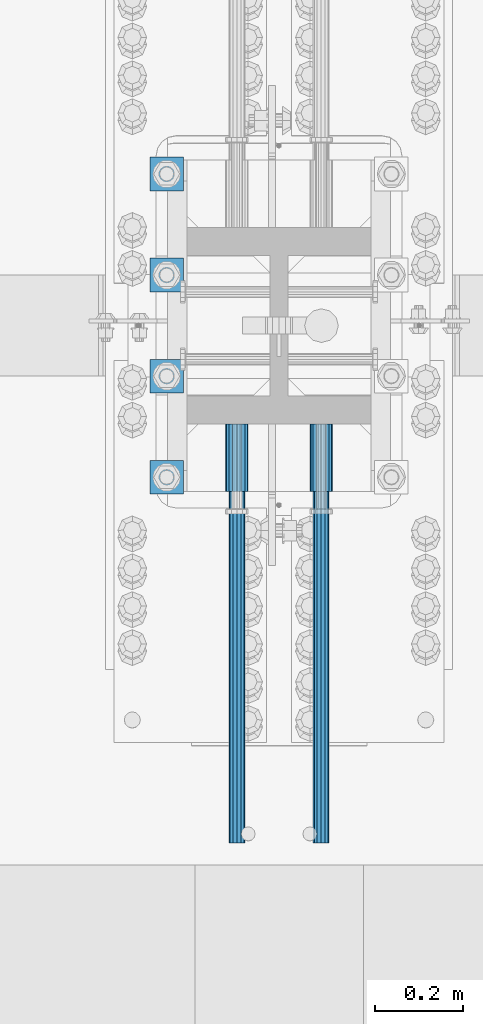
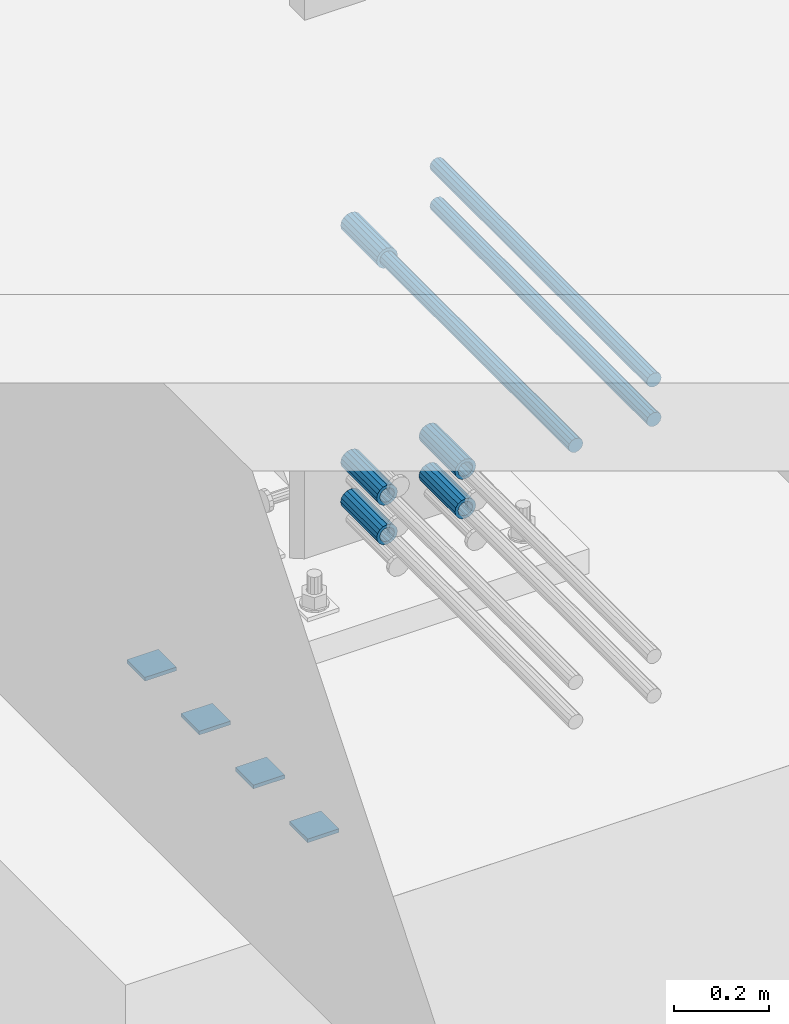
# One storey, part 1302 of 1763: 12 beams, 5 elements without a shape of their own.
"""IFC2X3 building model written with IfcOpenShell, lengths in millimetres."""

import ifcopenshell
import ifcopenshell.guid

model = None  # the IFC model being written
_history = None  # IfcOwnerHistory: only IFC2X3 demands one
_inside = {}  # id of a spatial element -> (the spatial element, [elements in it])
_under = {}  # id of a project, library or spatial element -> (it, [spatial elements below it])
_declared = {}  # id of a project -> (the project, [libraries it declares])
_typed = {}  # id of a type object -> (the type object, [elements of that type])
_made_of = {}  # id of a material, layer set ... -> (it, [elements and type objects made of it])


def new_model(schema):
    """Start an empty IFC model of exactly this schema.

    Asked for "IFC4X3", IfcOpenShell would pick the latest addendum, in which some entities
    have other attributes; the version numbers below select the first issue.
    IFC2X3 requires an IfcOwnerHistory on every rooted entity: one is made here for all.
    """
    global model, _history
    if schema == "IFC4X3":
        model = ifcopenshell.file(schema_version=(4, 3, 0, 0))
    else:
        model = ifcopenshell.file(schema=schema)
    _inside.clear()
    _under.clear()
    _declared.clear()
    _typed.clear()
    _made_of.clear()
    _history = None
    if model.schema == "IFC2X3":
        org = make("IfcOrganization", Name="unknown")
        user = make(
            "IfcPersonAndOrganization",
            ThePerson=make("IfcPerson", FamilyName="unknown"),
            TheOrganization=org,
        )
        app = make(
            "IfcApplication",
            ApplicationDeveloper=org,
            Version="unknown",
            ApplicationFullName="unknown",
            ApplicationIdentifier="unknown",
        )
        _history = make(
            "IfcOwnerHistory",
            OwningUser=user,
            OwningApplication=app,
            ChangeAction="ADDED",
            CreationDate=0,
        )
    return model


def make(cls, **values):
    """One entity of the class cls with the attributes given. An attribute that is None is left unset."""
    return model.create_entity(
        cls, **{name: value for name, value in values.items() if value is not None}
    )


def rooted(cls, **values):
    """An entity with a GlobalId (a new one), such as an element, a storey or a relation."""
    return make(cls, GlobalId=ifcopenshell.guid.new(), OwnerHistory=_history, **values)


def si_unit(unit_type, name, prefix=None):
    """IfcSIUnit, for example si_unit("LENGTHUNIT", "METRE", prefix="MILLI")."""
    return make("IfcSIUnit", UnitType=unit_type, Prefix=prefix, Name=name)


def assignment(units):
    """IfcUnitAssignment: the units of a project."""
    return None if units is None else make("IfcUnitAssignment", Units=units)


def point(xyz):
    """IfcCartesianPoint."""
    return None if xyz is None else make("IfcCartesianPoint", Coordinates=xyz)


def direction(xyz):
    """IfcDirection."""
    return None if xyz is None else make("IfcDirection", DirectionRatios=xyz)


def frame(location, z_axis=None, x_axis=None):
    """IfcAxis2Placement3D, a coordinate frame: its origin and axes. An axis left out is left unset."""
    return make(
        "IfcAxis2Placement3D",
        Location=point(location),
        Axis=direction(z_axis),
        RefDirection=direction(x_axis),
    )


def origin_with_axes():
    """The frame at (0, 0, 0) with the z axis (0, 0, 1) and the x axis (1, 0, 0) written out."""
    return frame((0.0, 0.0, 0.0), z_axis=(0.0, 0.0, 1.0), x_axis=(1.0, 0.0, 0.0))


def place(relative_to, where):
    """IfcLocalPlacement: puts the frame where relative to a parent placement (None: the world)."""
    return make(
        "IfcLocalPlacement", PlacementRelTo=relative_to, RelativePlacement=where
    )


def context(
    kind, dimensions, precision=None, world=None, true_north=None, identifier=None
):
    """IfcGeometricRepresentationContext, for example the 3D "Model" context."""
    return make(
        "IfcGeometricRepresentationContext",
        ContextIdentifier=identifier,
        ContextType=kind,
        CoordinateSpaceDimension=dimensions,
        Precision=precision,
        WorldCoordinateSystem=world,
        TrueNorth=true_north,
    )


def subcontext(parent, identifier, kind, view, scale=None):
    """IfcGeometricRepresentationSubContext, for example "Body" below "Model"."""
    return make(
        "IfcGeometricRepresentationSubContext",
        ContextIdentifier=identifier,
        ContextType=kind,
        ParentContext=parent,
        TargetScale=scale,
        TargetView=view,
    )


def project(units=None, contexts=None):
    """IfcProject with its units and contexts."""
    return rooted(
        "IfcProject",
        Name="project",
        RepresentationContexts=contexts,
        UnitsInContext=assignment(units),
    )


def spatial(cls, under=None, at=None, **own):
    """A site, building, storey or space (cls), placed at a placement, below another one or the project."""
    s = rooted(cls, ObjectPlacement=at, **own)
    if under is not None:
        _under.setdefault(under.id(), (under, []))[1].append(s)
    return s


def faces_of(points, faces, orient=None, outer=None):
    """IfcFace entities. A face is a list of loops; a loop is a list of indices into points, from 0.

    orient and outer hold one flag for each loop. By default every Orientation is true, the
    first loop of a face is its IfcFaceOuterBound and the others are IfcFaceBound.
    """
    made = []
    for i, loops in enumerate(faces):
        bounds = []
        for j, loop in enumerate(loops):
            is_outer = j == 0 if outer is None else outer[i][j]
            bounds.append(
                make(
                    "IfcFaceOuterBound" if is_outer else "IfcFaceBound",
                    Bound=make("IfcPolyLoop", Polygon=[points[k] for k in loop]),
                    Orientation=True if orient is None else orient[i][j],
                )
            )
        made.append(make("IfcFace", Bounds=bounds))
    return made


def faceted_brep(points, faces, orient=None, outer=None, voids=None):
    """IfcFacetedBrep: a solid bounded by flat faces; with voids (closed shells), ...WithVoids."""
    shared = [point(p) for p in points]
    hull = make("IfcClosedShell", CfsFaces=faces_of(shared, faces, orient, outer))
    if voids is None:
        return make("IfcFacetedBrep", Outer=hull)
    return make(
        "IfcFacetedBrepWithVoids",
        Outer=hull,
        Voids=[
            make(cls, CfsFaces=faces_of(shared, fs, o, b)) for cls, fs, o, b in voids
        ],
    )


def shape(context_of_items, identifier, shape_type, items):
    """IfcShapeRepresentation: the items that make up one representation, for example the "Body"."""
    return make(
        "IfcShapeRepresentation",
        ContextOfItems=context_of_items,
        RepresentationIdentifier=identifier,
        RepresentationType=shape_type,
        Items=items,
    )


def material(Name=None, Category=None):
    """IfcMaterial."""
    return make("IfcMaterial", Name=Name, Category=Category)


def made_of(thing, what):
    """Note that an element or type object is made of a material, layer set ...; save() writes the relation."""
    if what is not None:
        _made_of.setdefault(what.id(), (what, []))[1].append(thing)
    return thing


def type_object(cls, material=None, **own):
    """A type object (cls), such as IfcWallType, which elements share."""
    return made_of(rooted(cls, **own), material)


def element(
    cls,
    number,
    at=None,
    inside=None,
    cuts=None,
    type_object=None,
    material=None,
    context=None,
    identifier="Body",
    shape_type=None,
    held_by="IfcProductDefinitionShape",
    body=None,
    shapes=None,
    **own,
):
    """One element of the class cls, such as IfcWall. Its Tag is "e" and its number.

    at: its placement. inside: the storey or other place that contains it. cuts: it is an
    opening in that element (IfcRelVoidsElement). A single representation is given by context,
    identifier, shape_type and body (its items); several are given by shapes. held_by: the class
    of the entity that holds the representations. save() writes the other relations.
    """
    e = rooted(cls, Tag="e%d" % number, ObjectPlacement=at, **own)
    if body is not None:
        shapes = [shape(context, identifier, shape_type, body)]
    if shapes is not None:
        e.Representation = make(held_by, Representations=shapes)
    if inside is not None:
        _inside.setdefault(inside.id(), (inside, []))[1].append(e)
    if cuts is not None:
        rooted(
            "IfcRelVoidsElement", RelatingBuildingElement=cuts, RelatedOpeningElement=e
        )
    if type_object is not None:
        _typed.setdefault(type_object.id(), (type_object, []))[1].append(e)
    return made_of(e, material)


def aggregate(whole, parts):
    """IfcRelAggregates: a whole, such as a stair, and the parts it consists of."""
    return rooted("IfcRelAggregates", RelatingObject=whole, RelatedObjects=parts)


def save(model, path):
    """Write the relations noted so far, then the file.

    IfcRelAggregates (storeys below a building ...), IfcRelContainedInSpatialStructure (elements
    in a storey), IfcRelDefinesByType, IfcRelAssociatesMaterial and IfcRelDeclares: one each for
    every whole, place, type object, material and project.
    """
    for whole, parts in _under.values():
        aggregate(whole, parts)
    for where, things in _inside.values():
        rooted(
            "IfcRelContainedInSpatialStructure",
            RelatedElements=things,
            RelatingStructure=where,
        )
    for kind, things in _typed.values():
        rooted("IfcRelDefinesByType", RelatedObjects=things, RelatingType=kind)
    for what, things in _made_of.values():
        rooted("IfcRelAssociatesMaterial", RelatedObjects=things, RelatingMaterial=what)
    for by, libraries in _declared.values():
        rooted("IfcRelDeclares", RelatingContext=by, RelatedDefinitions=libraries)
    model.write(path)


model = new_model("IFC2X3")

# Units and contexts
model_context = context("Model", 3, precision=1e-05, world=origin_with_axes())
body_context = subcontext(model_context, "Body", "Model", "MODEL_VIEW")
ifc_project = project(units=[si_unit("LENGTHUNIT", "METRE", prefix="MILLI"), si_unit("AREAUNIT", "SQUARE_METRE"), si_unit("VOLUMEUNIT", "CUBIC_METRE"), si_unit("MASSUNIT", "GRAM", prefix="KILO"), si_unit("TIMEUNIT", "SECOND"), si_unit("PLANEANGLEUNIT", "RADIAN"), si_unit("SOLIDANGLEUNIT", "STERADIAN"), si_unit("THERMODYNAMICTEMPERATUREUNIT", "DEGREE_CELSIUS"), si_unit("LUMINOUSINTENSITYUNIT", "LUMEN")], contexts=[model_context])

# Site, building, storey
site_placement = place(None, origin_with_axes())
site = spatial("IfcSite", under=ifc_project, at=site_placement, CompositionType="ELEMENT")
building_placement = place(site_placement, origin_with_axes())
building = spatial("IfcBuilding", under=site, at=building_placement, Name="Undefined", CompositionType="ELEMENT")
storey_placement = place(building_placement, origin_with_axes())
storey = spatial("IfcBuildingStorey", under=building, at=storey_placement, Name="Undefined", CompositionType="ELEMENT", Elevation=0.0)

# Assembly, beams
assembly_1_placement = place(storey_placement, origin_with_axes())
assembly_1 = element("IfcElementAssembly", 1, at=assembly_1_placement, inside=storey, Name="TEMPLATE", AssemblyPlace="NOTDEFINED", PredefinedType="RIGID_FRAME")
ifc_material_1 = material(Name="STEEL/A36")
beam_type_1 = type_object("IfcBeamType", PredefinedType="NOTDEFINED")
beam_1_placement = place(assembly_1_placement, frame((-24281.8372736984, 76.1999999999981, 3348.0375), z_axis=(1.0, 0.0, 0.0), x_axis=(0.0, 1.0, 0.0)))
beam_1 = element("IfcBeam", 2, at=beam_1_placement, type_object=beam_type_1, material=ifc_material_1, Name="WASHER PLATE", context=body_context, shape_type="Brep", body=[
    faceted_brep([(0.0, 4.76249999999709, -38.1000000000004), (0.0, 4.76249999999709, 38.1000000000004), (76.2000000000007, 4.76249999999982, 38.0999999999985), (76.2000000000007, 4.76249999999982, -38.0999999999985), (0.0, -4.76249999999709, 38.1000000000004), (76.2000000000007, -4.76249999999982, 38.0999999999985), (0.0, -4.76249999999709, -38.1000000000004), (76.2000000000007, -4.76249999999982, -38.0999999999985)], [[[0, 1, 2, 3]], [[1, 4, 5, 2]], [[4, 6, 7, 5]], [[6, 0, 3, 7]], [[5, 7, 3, 2]], [[6, 4, 1, 0]]]),
])
beam_2_placement = place(assembly_1_placement, frame((-24281.8372736984, 304.799999999998, 3348.0375), z_axis=(1.0, 0.0, 0.0), x_axis=(0.0, 1.0, 0.0)))
beam_2 = element("IfcBeam", 3, at=beam_2_placement, type_object=beam_type_1, material=ifc_material_1, Name="WASHER PLATE", context=body_context, shape_type="Brep", body=[
    faceted_brep([(0.0, 4.76249999999709, -38.1000000000004), (0.0, 4.76249999999709, 38.1000000000004), (76.2000000000007, 4.76249999999982, 38.0999999999985), (76.2000000000007, 4.76249999999982, -38.0999999999985), (0.0, -4.76249999999709, 38.1000000000004), (76.2000000000007, -4.76249999999982, 38.0999999999985), (0.0, -4.76249999999709, -38.1000000000004), (76.2000000000007, -4.76249999999982, -38.0999999999985)], [[[0, 1, 2, 3]], [[1, 4, 5, 2]], [[4, 6, 7, 5]], [[6, 0, 3, 7]], [[5, 7, 3, 2]], [[6, 4, 1, 0]]]),
])
beam_3_placement = place(assembly_1_placement, frame((-24281.8372736984, 533.399999999998, 3348.0375), z_axis=(1.0, 0.0, 0.0), x_axis=(0.0, 1.0, 0.0)))
beam_3 = element("IfcBeam", 4, at=beam_3_placement, type_object=beam_type_1, material=ifc_material_1, Name="WASHER PLATE", context=body_context, shape_type="Brep", body=[
    faceted_brep([(0.0, 4.76249999999709, -38.1000000000004), (0.0, 4.76249999999709, 38.1000000000004), (76.2000000000007, 4.76249999999982, 38.0999999999985), (76.2000000000007, 4.76249999999982, -38.0999999999985), (0.0, -4.76249999999709, 38.1000000000004), (76.2000000000007, -4.76249999999982, 38.0999999999985), (0.0, -4.76249999999709, -38.1000000000004), (76.2000000000007, -4.76249999999982, -38.0999999999985)], [[[0, 1, 2, 3]], [[1, 4, 5, 2]], [[4, 6, 7, 5]], [[6, 0, 3, 7]], [[5, 7, 3, 2]], [[6, 4, 1, 0]]]),
])
beam_4_placement = place(assembly_1_placement, frame((-24281.8372736984, 761.999999999998, 3348.0375), z_axis=(1.0, 0.0, 0.0), x_axis=(0.0, 1.0, 0.0)))
beam_4 = element("IfcBeam", 5, at=beam_4_placement, type_object=beam_type_1, material=ifc_material_1, Name="WASHER PLATE", context=body_context, shape_type="Brep", body=[
    faceted_brep([(0.0, 4.76249999999709, -38.1000000000004), (0.0, 4.76249999999709, 38.1000000000004), (76.2000000000007, 4.76249999999982, 38.0999999999985), (76.2000000000007, 4.76249999999982, -38.0999999999985), (0.0, -4.76249999999709, 38.1000000000004), (76.2000000000007, -4.76249999999982, 38.0999999999985), (0.0, -4.76249999999709, -38.1000000000004), (76.2000000000007, -4.76249999999982, -38.0999999999985)], [[[0, 1, 2, 3]], [[1, 4, 5, 2]], [[4, 6, 7, 5]], [[6, 0, 3, 7]], [[5, 7, 3, 2]], [[6, 4, 1, 0]]]),
])
aggregate(assembly_1, [beam_1, beam_2, beam_3, beam_4])

assembly_2_placement = place(storey_placement, origin_with_axes())
assembly_2 = element("IfcElementAssembly", 6, at=assembly_2_placement, inside=storey, Name="COLUMN", AssemblyPlace="NOTDEFINED", PredefinedType="RIGID_FRAME")
ifc_material_2 = material(Name="STEEL/A706-GR.80")
beam_type_2 = type_object("IfcBeamType", PredefinedType="NOTDEFINED")
beam_5_placement = place(assembly_2_placement, frame((-24123.0872736984, 234.764353525459, 4064.0), z_axis=(0.0, 0.0, 1.0), x_axis=(0.0, -1.0, 0.0)))
beam_5 = element("IfcBeam", 7, at=beam_5_placement, type_object=beam_type_2, material=ifc_material_2, Name="HALF COUPLER F", context=body_context, shape_type="Brep", body=[
    faceted_brep([(32.7659999999996, -8.95349999999962, -15.507916905568), (32.7659999999996, 0.0, -17.9070000000002), (32.7659999999996, 8.95349999999962, -15.507916905568), (32.7659999999996, 15.507916905568, -8.95350000000008), (32.7659999999996, 17.9069999999992, 0.0), (32.7659999999996, 15.507916905568, 8.95350000000008), (32.7659999999996, 8.95349999999962, 15.507916905568), (32.7659999999996, 0.0, 17.9070000000002), (32.7659999999996, -8.95349999999962, 15.507916905568), (32.7659999999996, -15.507916905568, 8.95350000000008), (32.7659999999996, -17.9069999999992, 0.0), (32.7659999999996, -15.507916905568, -8.95350000000008), (152.400103102711, -15.507916905568, 8.95350000000008), (152.400103102711, -8.95349999999962, 15.507916905568), (152.400103102711, -17.9069999999992, 0.0), (152.400103102711, -15.507916905568, -8.95350000000008), (152.400103102711, -8.95349999999962, -15.507916905568), (152.400103102711, 0.0, -17.9070000000002), (152.400103102711, 8.95349999999962, -15.507916905568), (152.400103102711, 15.507916905568, -8.95350000000008), (152.400103102711, 17.9069999999992, 0.0), (152.400103102711, 15.507916905568, 8.95350000000008), (152.400103102711, 8.95349999999962, 15.507916905568), (152.400103102711, 0.0, 17.9070000000002), (0.0, -23.466540125788, 9.72015918207308), (0.0, -17.9605122421381, 17.9605122421385), (0.0, -9.72015918207398, 23.4665401257867), (0.0, 0.0, 25.4000000000001), (0.0, 9.72015918207398, 23.4665401257867), (0.0, 17.9605122421381, 17.9605122421385), (0.0, 23.466540125788, 9.72015918207308), (0.0, 25.4000000000015, 0.0), (0.0, 23.466540125788, -9.72015918207308), (0.0, 17.9605122421381, -17.9605122421385), (0.0, 9.72015918207398, -23.4665401257867), (0.0, 0.0, -25.4000000000001), (0.0, -9.72015918207398, -23.4665401257867), (0.0, -17.9605122421381, -17.9605122421385), (0.0, -23.466540125788, -9.72015918207308), (0.0, -25.4000000000015, 0.0), (152.400103102711, -25.4000000000015, 0.0), (152.400103102711, -23.466540125788, 9.72015918207308), (152.400103102711, -17.9605122421381, 17.9605122421385), (152.400103102711, -9.72015918207398, 23.4665401257867), (152.400103102711, 0.0, 25.4000000000001), (152.400103102711, 9.72015918207398, 23.4665401257867), (152.400103102711, 17.9605122421381, 17.9605122421385), (152.400103102711, 23.466540125788, 9.72015918207308), (152.400103102711, 25.4000000000015, 0.0), (152.400103102711, 23.466540125788, -9.72015918207308), (152.400103102711, 17.9605122421381, -17.9605122421385), (152.400103102711, 9.72015918207398, -23.4665401257867), (152.400103102711, 0.0, -25.4000000000001), (152.400103102711, -9.72015918207398, -23.4665401257867), (152.400103102711, -17.9605122421381, -17.9605122421385), (152.400103102711, -23.466540125788, -9.72015918207308)], [[[0, 1, 2, 3, 4, 5, 6, 7, 8, 9, 10, 11]], [[12, 9, 8, 13]], [[14, 10, 9, 12]], [[15, 11, 10, 14]], [[16, 0, 11, 15]], [[17, 1, 0, 16]], [[18, 2, 1, 17]], [[19, 3, 2, 18]], [[20, 4, 3, 19]], [[21, 5, 4, 20]], [[22, 6, 5, 21]], [[23, 7, 6, 22]], [[13, 8, 7, 23]], [[24, 25, 26, 27, 28, 29, 30, 31, 32, 33, 34, 35, 36, 37, 38, 39]], [[24, 39, 40, 41]], [[25, 24, 41, 42]], [[26, 25, 42, 43]], [[27, 26, 43, 44]], [[28, 27, 44, 45]], [[29, 28, 45, 46]], [[30, 29, 46, 47]], [[31, 30, 47, 48]], [[32, 31, 48, 49]], [[33, 32, 49, 50]], [[34, 33, 50, 51]], [[35, 34, 51, 52]], [[36, 35, 52, 53]], [[37, 36, 53, 54]], [[38, 37, 54, 55]], [[39, 38, 55, 40]], [[54, 53, 52, 51, 50, 49, 48, 47, 46, 45, 44, 43, 42, 41, 40, 55], [21, 20, 19, 18, 17, 16, 15, 14, 12, 13, 23, 22]]]),
])
beam_6_placement = place(assembly_2_placement, frame((-23932.5872736985, 234.764422260983, 4064.0), z_axis=(0.0, 0.0, 1.0), x_axis=(0.0, -1.0, 0.0)))
beam_6 = element("IfcBeam", 8, at=beam_6_placement, type_object=beam_type_2, material=ifc_material_2, Name="HALF COUPLER F", context=body_context, shape_type="Brep", body=[
    faceted_brep([(32.7659999999996, -8.95349999999962, -15.507916905568), (32.7659999999996, 0.0, -17.9070000000002), (32.7659999999996, 8.95349999999962, -15.507916905568), (32.7659999999996, 15.507916905568, -8.95350000000008), (32.7659999999996, 17.9069999999992, 0.0), (32.7659999999996, 15.507916905568, 8.95350000000008), (32.7659999999996, 8.95349999999962, 15.507916905568), (32.7659999999996, 0.0, 17.9070000000002), (32.7659999999996, -8.95349999999962, 15.507916905568), (32.7659999999996, -15.507916905568, 8.95350000000008), (32.7659999999996, -17.9069999999992, 0.0), (32.7659999999996, -15.507916905568, -8.95350000000008), (152.400103102711, -15.507916905568, 8.95350000000008), (152.400103102711, -8.95349999999962, 15.507916905568), (152.400103102711, -17.9069999999992, 0.0), (152.400103102711, -15.507916905568, -8.95350000000008), (152.400103102711, -8.95349999999962, -15.507916905568), (152.400103102711, 0.0, -17.9070000000002), (152.400103102711, 8.95349999999962, -15.507916905568), (152.400103102711, 15.507916905568, -8.95350000000008), (152.400103102711, 17.9069999999992, 0.0), (152.400103102711, 15.507916905568, 8.95350000000008), (152.400103102711, 8.95349999999962, 15.507916905568), (152.400103102711, 0.0, 17.9070000000002), (0.0, -23.466540125788, 9.72015918207308), (0.0, -17.9605122421381, 17.9605122421385), (0.0, -9.72015918207398, 23.4665401257867), (0.0, 0.0, 25.4000000000001), (0.0, 9.72015918207398, 23.4665401257867), (0.0, 17.9605122421381, 17.9605122421385), (0.0, 23.466540125788, 9.72015918207308), (0.0, 25.4000000000015, 0.0), (0.0, 23.466540125788, -9.72015918207308), (0.0, 17.9605122421381, -17.9605122421385), (0.0, 9.72015918207398, -23.4665401257867), (0.0, 0.0, -25.4000000000001), (0.0, -9.72015918207398, -23.4665401257867), (0.0, -17.9605122421381, -17.9605122421385), (0.0, -23.466540125788, -9.72015918207308), (0.0, -25.4000000000015, 0.0), (152.400103102711, -25.4000000000015, 0.0), (152.400103102711, -23.466540125788, 9.72015918207308), (152.400103102711, -17.9605122421381, 17.9605122421385), (152.400103102711, -9.72015918207398, 23.4665401257867), (152.400103102711, 0.0, 25.4000000000001), (152.400103102711, 9.72015918207398, 23.4665401257867), (152.400103102711, 17.9605122421381, 17.9605122421385), (152.400103102711, 23.466540125788, 9.72015918207308), (152.400103102711, 25.4000000000015, 0.0), (152.400103102711, 23.466540125788, -9.72015918207308), (152.400103102711, 17.9605122421381, -17.9605122421385), (152.400103102711, 9.72015918207398, -23.4665401257867), (152.400103102711, 0.0, -25.4000000000001), (152.400103102711, -9.72015918207398, -23.4665401257867), (152.400103102711, -17.9605122421381, -17.9605122421385), (152.400103102711, -23.466540125788, -9.72015918207308)], [[[0, 1, 2, 3, 4, 5, 6, 7, 8, 9, 10, 11]], [[12, 9, 8, 13]], [[14, 10, 9, 12]], [[15, 11, 10, 14]], [[16, 0, 11, 15]], [[17, 1, 0, 16]], [[18, 2, 1, 17]], [[19, 3, 2, 18]], [[20, 4, 3, 19]], [[21, 5, 4, 20]], [[22, 6, 5, 21]], [[23, 7, 6, 22]], [[13, 8, 7, 23]], [[24, 25, 26, 27, 28, 29, 30, 31, 32, 33, 34, 35, 36, 37, 38, 39]], [[24, 39, 40, 41]], [[25, 24, 41, 42]], [[26, 25, 42, 43]], [[27, 26, 43, 44]], [[28, 27, 44, 45]], [[29, 28, 45, 46]], [[30, 29, 46, 47]], [[31, 30, 47, 48]], [[32, 31, 48, 49]], [[33, 32, 49, 50]], [[34, 33, 50, 51]], [[35, 34, 51, 52]], [[36, 35, 52, 53]], [[37, 36, 53, 54]], [[38, 37, 54, 55]], [[39, 38, 55, 40]], [[54, 53, 52, 51, 50, 49, 48, 47, 46, 45, 44, 43, 42, 41, 40, 55], [21, 20, 19, 18, 17, 16, 15, 14, 12, 13, 23, 22]]]),
])
beam_7_placement = place(assembly_2_placement, frame((-24123.0872736984, 234.764353525458, 4165.6), z_axis=(0.0, 0.0, 1.0), x_axis=(0.0, -1.0, 0.0)))
beam_7 = element("IfcBeam", 9, at=beam_7_placement, type_object=beam_type_2, material=ifc_material_2, Name="HALF COUPLER F", context=body_context, shape_type="Brep", body=[
    faceted_brep([(32.7659999999996, -8.95349999999962, -15.507916905568), (32.7659999999996, 0.0, -17.9070000000002), (32.7659999999996, 8.95349999999962, -15.507916905568), (32.7659999999996, 15.507916905568, -8.95350000000008), (32.7659999999996, 17.9069999999992, 0.0), (32.7659999999996, 15.507916905568, 8.95350000000008), (32.7659999999996, 8.95349999999962, 15.507916905568), (32.7659999999996, 0.0, 17.9070000000002), (32.7659999999996, -8.95349999999962, 15.507916905568), (32.7659999999996, -15.507916905568, 8.95350000000008), (32.7659999999996, -17.9069999999992, 0.0), (32.7659999999996, -15.507916905568, -8.95350000000008), (152.400103102711, -15.507916905568, 8.95350000000008), (152.400103102711, -8.95349999999962, 15.507916905568), (152.400103102711, -17.9069999999992, 0.0), (152.400103102711, -15.507916905568, -8.95350000000008), (152.400103102711, -8.95349999999962, -15.507916905568), (152.400103102711, 0.0, -17.9070000000002), (152.400103102711, 8.95349999999962, -15.507916905568), (152.400103102711, 15.507916905568, -8.95350000000008), (152.400103102711, 17.9069999999992, 0.0), (152.400103102711, 15.507916905568, 8.95350000000008), (152.400103102711, 8.95349999999962, 15.507916905568), (152.400103102711, 0.0, 17.9070000000002), (0.0, -23.466540125788, 9.72015918207308), (0.0, -17.9605122421381, 17.9605122421385), (0.0, -9.72015918207398, 23.4665401257867), (0.0, 0.0, 25.4000000000001), (0.0, 9.72015918207398, 23.4665401257867), (0.0, 17.9605122421381, 17.9605122421385), (0.0, 23.466540125788, 9.72015918207308), (0.0, 25.4000000000015, 0.0), (0.0, 23.466540125788, -9.72015918207308), (0.0, 17.9605122421381, -17.9605122421385), (0.0, 9.72015918207398, -23.4665401257867), (0.0, 0.0, -25.4000000000001), (0.0, -9.72015918207398, -23.4665401257867), (0.0, -17.9605122421381, -17.9605122421385), (0.0, -23.466540125788, -9.72015918207308), (0.0, -25.4000000000015, 0.0), (152.400103102711, -25.4000000000015, 0.0), (152.400103102711, -23.466540125788, 9.72015918207308), (152.400103102711, -17.9605122421381, 17.9605122421385), (152.400103102711, -9.72015918207398, 23.4665401257867), (152.400103102711, 0.0, 25.4000000000001), (152.400103102711, 9.72015918207398, 23.4665401257867), (152.400103102711, 17.9605122421381, 17.9605122421385), (152.400103102711, 23.466540125788, 9.72015918207308), (152.400103102711, 25.4000000000015, 0.0), (152.400103102711, 23.466540125788, -9.72015918207308), (152.400103102711, 17.9605122421381, -17.9605122421385), (152.400103102711, 9.72015918207398, -23.4665401257867), (152.400103102711, 0.0, -25.4000000000001), (152.400103102711, -9.72015918207398, -23.4665401257867), (152.400103102711, -17.9605122421381, -17.9605122421385), (152.400103102711, -23.466540125788, -9.72015918207308)], [[[0, 1, 2, 3, 4, 5, 6, 7, 8, 9, 10, 11]], [[12, 9, 8, 13]], [[14, 10, 9, 12]], [[15, 11, 10, 14]], [[16, 0, 11, 15]], [[17, 1, 0, 16]], [[18, 2, 1, 17]], [[19, 3, 2, 18]], [[20, 4, 3, 19]], [[21, 5, 4, 20]], [[22, 6, 5, 21]], [[23, 7, 6, 22]], [[13, 8, 7, 23]], [[24, 25, 26, 27, 28, 29, 30, 31, 32, 33, 34, 35, 36, 37, 38, 39]], [[24, 39, 40, 41]], [[25, 24, 41, 42]], [[26, 25, 42, 43]], [[27, 26, 43, 44]], [[28, 27, 44, 45]], [[29, 28, 45, 46]], [[30, 29, 46, 47]], [[31, 30, 47, 48]], [[32, 31, 48, 49]], [[33, 32, 49, 50]], [[34, 33, 50, 51]], [[35, 34, 51, 52]], [[36, 35, 52, 53]], [[37, 36, 53, 54]], [[38, 37, 54, 55]], [[39, 38, 55, 40]], [[54, 53, 52, 51, 50, 49, 48, 47, 46, 45, 44, 43, 42, 41, 40, 55], [21, 20, 19, 18, 17, 16, 15, 14, 12, 13, 23, 22]]]),
])
beam_8_placement = place(assembly_2_placement, frame((-23932.5872736985, 234.764422260982, 4165.6), z_axis=(0.0, 0.0, 1.0), x_axis=(0.0, -1.0, 0.0)))
beam_8 = element("IfcBeam", 10, at=beam_8_placement, type_object=beam_type_2, material=ifc_material_2, Name="HALF COUPLER F", context=body_context, shape_type="Brep", body=[
    faceted_brep([(32.7659999999996, -8.95349999999962, -15.507916905568), (32.7659999999996, 0.0, -17.9070000000002), (32.7659999999996, 8.95349999999962, -15.507916905568), (32.7659999999996, 15.507916905568, -8.95350000000008), (32.7659999999996, 17.9069999999992, 0.0), (32.7659999999996, 15.507916905568, 8.95350000000008), (32.7659999999996, 8.95349999999962, 15.507916905568), (32.7659999999996, 0.0, 17.9070000000002), (32.7659999999996, -8.95349999999962, 15.507916905568), (32.7659999999996, -15.507916905568, 8.95350000000008), (32.7659999999996, -17.9069999999992, 0.0), (32.7659999999996, -15.507916905568, -8.95350000000008), (152.400103102711, -15.507916905568, 8.95350000000008), (152.400103102711, -8.95349999999962, 15.507916905568), (152.400103102711, -17.9069999999992, 0.0), (152.400103102711, -15.507916905568, -8.95350000000008), (152.400103102711, -8.95349999999962, -15.507916905568), (152.400103102711, 0.0, -17.9070000000002), (152.400103102711, 8.95349999999962, -15.507916905568), (152.400103102711, 15.507916905568, -8.95350000000008), (152.400103102711, 17.9069999999992, 0.0), (152.400103102711, 15.507916905568, 8.95350000000008), (152.400103102711, 8.95349999999962, 15.507916905568), (152.400103102711, 0.0, 17.9070000000002), (0.0, -23.466540125788, 9.72015918207308), (0.0, -17.9605122421381, 17.9605122421385), (0.0, -9.72015918207398, 23.4665401257867), (0.0, 0.0, 25.4000000000001), (0.0, 9.72015918207398, 23.4665401257867), (0.0, 17.9605122421381, 17.9605122421385), (0.0, 23.466540125788, 9.72015918207308), (0.0, 25.4000000000015, 0.0), (0.0, 23.466540125788, -9.72015918207308), (0.0, 17.9605122421381, -17.9605122421385), (0.0, 9.72015918207398, -23.4665401257867), (0.0, 0.0, -25.4000000000001), (0.0, -9.72015918207398, -23.4665401257867), (0.0, -17.9605122421381, -17.9605122421385), (0.0, -23.466540125788, -9.72015918207308), (0.0, -25.4000000000015, 0.0), (152.400103102711, -25.4000000000015, 0.0), (152.400103102711, -23.466540125788, 9.72015918207308), (152.400103102711, -17.9605122421381, 17.9605122421385), (152.400103102711, -9.72015918207398, 23.4665401257867), (152.400103102711, 0.0, 25.4000000000001), (152.400103102711, 9.72015918207398, 23.4665401257867), (152.400103102711, 17.9605122421381, 17.9605122421385), (152.400103102711, 23.466540125788, 9.72015918207308), (152.400103102711, 25.4000000000015, 0.0), (152.400103102711, 23.466540125788, -9.72015918207308), (152.400103102711, 17.9605122421381, -17.9605122421385), (152.400103102711, 9.72015918207398, -23.4665401257867), (152.400103102711, 0.0, -25.4000000000001), (152.400103102711, -9.72015918207398, -23.4665401257867), (152.400103102711, -17.9605122421381, -17.9605122421385), (152.400103102711, -23.466540125788, -9.72015918207308)], [[[0, 1, 2, 3, 4, 5, 6, 7, 8, 9, 10, 11]], [[12, 9, 8, 13]], [[14, 10, 9, 12]], [[15, 11, 10, 14]], [[16, 0, 11, 15]], [[17, 1, 0, 16]], [[18, 2, 1, 17]], [[19, 3, 2, 18]], [[20, 4, 3, 19]], [[21, 5, 4, 20]], [[22, 6, 5, 21]], [[23, 7, 6, 22]], [[13, 8, 7, 23]], [[24, 25, 26, 27, 28, 29, 30, 31, 32, 33, 34, 35, 36, 37, 38, 39]], [[24, 39, 40, 41]], [[25, 24, 41, 42]], [[26, 25, 42, 43]], [[27, 26, 43, 44]], [[28, 27, 44, 45]], [[29, 28, 45, 46]], [[30, 29, 46, 47]], [[31, 30, 47, 48]], [[32, 31, 48, 49]], [[33, 32, 49, 50]], [[34, 33, 50, 51]], [[35, 34, 51, 52]], [[36, 35, 52, 53]], [[37, 36, 53, 54]], [[38, 37, 54, 55]], [[39, 38, 55, 40]], [[54, 53, 52, 51, 50, 49, 48, 47, 46, 45, 44, 43, 42, 41, 40, 55], [21, 20, 19, 18, 17, 16, 15, 14, 12, 13, 23, 22]]]),
])
beam_9_placement = place(assembly_2_placement, frame((-24123.0872736984, 234.76421605501, 4775.20000000009), z_axis=(0.0, 0.0, 1.0), x_axis=(0.0, -1.0, 0.0)))
beam_9 = element("IfcBeam", 11, at=beam_9_placement, type_object=beam_type_2, material=ifc_material_2, Name="HALF COUPLER F", context=body_context, shape_type="Brep", body=[
    faceted_brep([(32.7659999999996, -8.95349999999962, -15.507916905568), (32.7659999999996, 0.0, -17.9070000000002), (32.7659999999996, 8.95349999999962, -15.507916905568), (32.7659999999996, 15.507916905568, -8.95350000000008), (32.7659999999996, 17.9069999999992, 0.0), (32.7659999999996, 15.507916905568, 8.95350000000008), (32.7659999999996, 8.95349999999962, 15.507916905568), (32.7659999999996, 0.0, 17.9070000000002), (32.7659999999996, -8.95349999999962, 15.507916905568), (32.7659999999996, -15.507916905568, 8.95350000000008), (32.7659999999996, -17.9069999999992, 0.0), (32.7659999999996, -15.507916905568, -8.95350000000008), (152.400103102711, -15.507916905568, 8.95350000000008), (152.400103102711, -8.95349999999962, 15.507916905568), (152.400103102711, -17.9069999999992, 0.0), (152.400103102711, -15.507916905568, -8.95350000000008), (152.400103102711, -8.95349999999962, -15.507916905568), (152.400103102711, 0.0, -17.9070000000002), (152.400103102711, 8.95349999999962, -15.507916905568), (152.400103102711, 15.507916905568, -8.95350000000008), (152.400103102711, 17.9069999999992, 0.0), (152.400103102711, 15.507916905568, 8.95350000000008), (152.400103102711, 8.95349999999962, 15.507916905568), (152.400103102711, 0.0, 17.9070000000002), (0.0, -23.466540125788, 9.72015918207308), (0.0, -17.9605122421381, 17.9605122421385), (0.0, -9.72015918207398, 23.4665401257867), (0.0, 0.0, 25.4000000000001), (0.0, 9.72015918207398, 23.4665401257867), (0.0, 17.9605122421381, 17.9605122421385), (0.0, 23.466540125788, 9.72015918207308), (0.0, 25.4000000000015, 0.0), (0.0, 23.466540125788, -9.72015918207308), (0.0, 17.9605122421381, -17.9605122421385), (0.0, 9.72015918207398, -23.4665401257867), (0.0, 0.0, -25.4000000000001), (0.0, -9.72015918207398, -23.4665401257867), (0.0, -17.9605122421381, -17.9605122421385), (0.0, -23.466540125788, -9.72015918207308), (0.0, -25.4000000000015, 0.0), (152.400103102711, -25.4000000000015, 0.0), (152.400103102711, -23.466540125788, 9.72015918207308), (152.400103102711, -17.9605122421381, 17.9605122421385), (152.400103102711, -9.72015918207398, 23.4665401257867), (152.400103102711, 0.0, 25.4000000000001), (152.400103102711, 9.72015918207398, 23.4665401257867), (152.400103102711, 17.9605122421381, 17.9605122421385), (152.400103102711, 23.466540125788, 9.72015918207308), (152.400103102711, 25.4000000000015, 0.0), (152.400103102711, 23.466540125788, -9.72015918207308), (152.400103102711, 17.9605122421381, -17.9605122421385), (152.400103102711, 9.72015918207398, -23.4665401257867), (152.400103102711, 0.0, -25.4000000000001), (152.400103102711, -9.72015918207398, -23.4665401257867), (152.400103102711, -17.9605122421381, -17.9605122421385), (152.400103102711, -23.466540125788, -9.72015918207308)], [[[0, 1, 2, 3, 4, 5, 6, 7, 8, 9, 10, 11]], [[12, 9, 8, 13]], [[14, 10, 9, 12]], [[15, 11, 10, 14]], [[16, 0, 11, 15]], [[17, 1, 0, 16]], [[18, 2, 1, 17]], [[19, 3, 2, 18]], [[20, 4, 3, 19]], [[21, 5, 4, 20]], [[22, 6, 5, 21]], [[23, 7, 6, 22]], [[13, 8, 7, 23]], [[24, 25, 26, 27, 28, 29, 30, 31, 32, 33, 34, 35, 36, 37, 38, 39]], [[24, 39, 40, 41]], [[25, 24, 41, 42]], [[26, 25, 42, 43]], [[27, 26, 43, 44]], [[28, 27, 44, 45]], [[29, 28, 45, 46]], [[30, 29, 46, 47]], [[31, 30, 47, 48]], [[32, 31, 48, 49]], [[33, 32, 49, 50]], [[34, 33, 50, 51]], [[35, 34, 51, 52]], [[36, 35, 52, 53]], [[37, 36, 53, 54]], [[38, 37, 54, 55]], [[39, 38, 55, 40]], [[54, 53, 52, 51, 50, 49, 48, 47, 46, 45, 44, 43, 42, 41, 40, 55], [21, 20, 19, 18, 17, 16, 15, 14, 12, 13, 23, 22]]]),
])
aggregate(assembly_2, [beam_5, beam_6, beam_7, beam_8, beam_9])

# Assembly, beam
assembly_3_placement = place(storey_placement, origin_with_axes())
assembly_3 = element("IfcElementAssembly", 12, at=assembly_3_placement, inside=storey, Name="REBAR", AssemblyPlace="NOTDEFINED", PredefinedType="RIGID_FRAME")
beam_type_3 = type_object("IfcBeamType", Name="#11 REBAR", PredefinedType="NOTDEFINED")
beam_10_placement = place(assembly_3_placement, frame((-23932.5872736984, 201.998078658984, 4876.80000000009), z_axis=(0.0, 0.0, 1.0), x_axis=(0.0, -1.0, 0.0)))
beam_10 = element("IfcBeam", 13, at=beam_10_placement, type_object=beam_type_3, material=ifc_material_2, Name="REBAR", ObjectType="#11 REBAR", context=body_context, shape_type="Brep", body=[
    faceted_brep([(0.0, -17.9069999999992, 0.0), (0.0, -15.507916905568, -8.95349999999962), (914.400000001086, -15.507916905568, -8.95349999999962), (914.400000001086, -17.9069999999992, 0.0), (0.0, -8.95349999999962, -15.507916905568), (914.400000001086, -8.95349999999962, -15.507916905568), (0.0, 0.0, -17.9070000000002), (914.400000001086, 0.0, -17.9070000000002), (0.0, 8.95349999999962, -15.507916905568), (914.400000001086, 8.95349999999962, -15.507916905568), (0.0, 15.507916905568, -8.95349999999962), (914.400000001086, 15.507916905568, -8.95349999999962), (0.0, 17.9069999999992, 0.0), (914.400000001086, 17.9069999999992, 0.0), (0.0, 15.507916905568, 8.95349999999962), (914.400000001086, 15.507916905568, 8.95349999999962), (0.0, 8.95349999999962, 15.507916905568), (914.400000001086, 8.95349999999962, 15.507916905568), (0.0, 0.0, 17.9070000000002), (914.400000001086, 0.0, 17.9070000000002), (0.0, -8.95349999999962, 15.507916905568), (914.400000001086, -8.95349999999962, 15.507916905568), (0.0, -15.507916905568, 8.95349999999962), (914.400000001086, -15.507916905568, 8.95349999999962)], [[[0, 1, 2, 3]], [[1, 4, 5, 2]], [[4, 6, 7, 5]], [[6, 8, 9, 7]], [[8, 10, 11, 9]], [[10, 12, 13, 11]], [[12, 14, 15, 13]], [[14, 16, 17, 15]], [[16, 18, 19, 17]], [[18, 20, 21, 19]], [[20, 22, 23, 21]], [[22, 0, 3, 23]], [[5, 7, 9, 11, 13, 15, 17, 19, 21, 23, 3, 2]], [[22, 20, 18, 16, 14, 12, 10, 8, 6, 4, 1, 0]]]),
])
aggregate(assembly_3, [beam_10])

assembly_4_placement = place(storey_placement, origin_with_axes())
assembly_4 = element("IfcElementAssembly", 14, at=assembly_4_placement, inside=storey, Name="REBAR", AssemblyPlace="NOTDEFINED", PredefinedType="RIGID_FRAME")
beam_11_placement = place(assembly_4_placement, frame((-24123.0872736977, 201.998147319484, 4775.20000000009), z_axis=(0.0, 0.0, 1.0), x_axis=(0.0, -1.0, 0.0)))
beam_11 = element("IfcBeam", 15, at=beam_11_placement, type_object=beam_type_3, material=ifc_material_2, Name="REBAR", ObjectType="#11 REBAR", context=body_context, shape_type="Brep", body=[
    faceted_brep([(0.0, -17.9069999999992, 0.0), (0.0, -15.507916905568, -8.95349999999962), (914.400000001086, -15.507916905568, -8.95349999999962), (914.400000001086, -17.9069999999992, 0.0), (0.0, -8.95349999999962, -15.507916905568), (914.400000001086, -8.95349999999962, -15.507916905568), (0.0, 0.0, -17.9070000000002), (914.400000001086, 0.0, -17.9070000000002), (0.0, 8.95349999999962, -15.507916905568), (914.400000001086, 8.95349999999962, -15.507916905568), (0.0, 15.507916905568, -8.95349999999962), (914.400000001086, 15.507916905568, -8.95349999999962), (0.0, 17.9069999999992, 0.0), (914.400000001086, 17.9069999999992, 0.0), (0.0, 15.507916905568, 8.95349999999962), (914.400000001086, 15.507916905568, 8.95349999999962), (0.0, 8.95349999999962, 15.507916905568), (914.400000001086, 8.95349999999962, 15.507916905568), (0.0, 0.0, 17.9070000000002), (914.400000001086, 0.0, 17.9070000000002), (0.0, -8.95349999999962, 15.507916905568), (914.400000001086, -8.95349999999962, 15.507916905568), (0.0, -15.507916905568, 8.95349999999962), (914.400000001086, -15.507916905568, 8.95349999999962)], [[[0, 1, 2, 3]], [[1, 4, 5, 2]], [[4, 6, 7, 5]], [[6, 8, 9, 7]], [[8, 10, 11, 9]], [[10, 12, 13, 11]], [[12, 14, 15, 13]], [[14, 16, 17, 15]], [[16, 18, 19, 17]], [[18, 20, 21, 19]], [[20, 22, 23, 21]], [[22, 0, 3, 23]], [[5, 7, 9, 11, 13, 15, 17, 19, 21, 23, 3, 2]], [[22, 20, 18, 16, 14, 12, 10, 8, 6, 4, 1, 0]]]),
])
aggregate(assembly_4, [beam_11])

assembly_5_placement = place(storey_placement, origin_with_axes())
assembly_5 = element("IfcElementAssembly", 16, at=assembly_5_placement, inside=storey, Name="REBAR", AssemblyPlace="NOTDEFINED", PredefinedType="RIGID_FRAME")
beam_12_placement = place(assembly_5_placement, frame((-23932.5872736984, 201.998078658982, 4775.20000000009), z_axis=(0.0, 0.0, 1.0), x_axis=(0.0, -1.0, 0.0)))
beam_12 = element("IfcBeam", 17, at=beam_12_placement, type_object=beam_type_3, material=ifc_material_2, Name="REBAR", ObjectType="#11 REBAR", context=body_context, shape_type="Brep", body=[
    faceted_brep([(0.0, -17.9069999999992, 0.0), (0.0, -15.507916905568, -8.95349999999962), (914.400000001086, -15.507916905568, -8.95349999999962), (914.400000001086, -17.9069999999992, 0.0), (0.0, -8.95349999999962, -15.507916905568), (914.400000001086, -8.95349999999962, -15.507916905568), (0.0, 0.0, -17.9070000000002), (914.400000001086, 0.0, -17.9070000000002), (0.0, 8.95349999999962, -15.507916905568), (914.400000001086, 8.95349999999962, -15.507916905568), (0.0, 15.507916905568, -8.95349999999962), (914.400000001086, 15.507916905568, -8.95349999999962), (0.0, 17.9069999999992, 0.0), (914.400000001086, 17.9069999999992, 0.0), (0.0, 15.507916905568, 8.95349999999962), (914.400000001086, 15.507916905568, 8.95349999999962), (0.0, 8.95349999999962, 15.507916905568), (914.400000001086, 8.95349999999962, 15.507916905568), (0.0, 0.0, 17.9070000000002), (914.400000001086, 0.0, 17.9070000000002), (0.0, -8.95349999999962, 15.507916905568), (914.400000001086, -8.95349999999962, 15.507916905568), (0.0, -15.507916905568, 8.95349999999962), (914.400000001086, -15.507916905568, 8.95349999999962)], [[[0, 1, 2, 3]], [[1, 4, 5, 2]], [[4, 6, 7, 5]], [[6, 8, 9, 7]], [[8, 10, 11, 9]], [[10, 12, 13, 11]], [[12, 14, 15, 13]], [[14, 16, 17, 15]], [[16, 18, 19, 17]], [[18, 20, 21, 19]], [[20, 22, 23, 21]], [[22, 0, 3, 23]], [[5, 7, 9, 11, 13, 15, 17, 19, 21, 23, 3, 2]], [[22, 20, 18, 16, 14, 12, 10, 8, 6, 4, 1, 0]]]),
])
aggregate(assembly_5, [beam_12])

save(model, "model.ifc")
